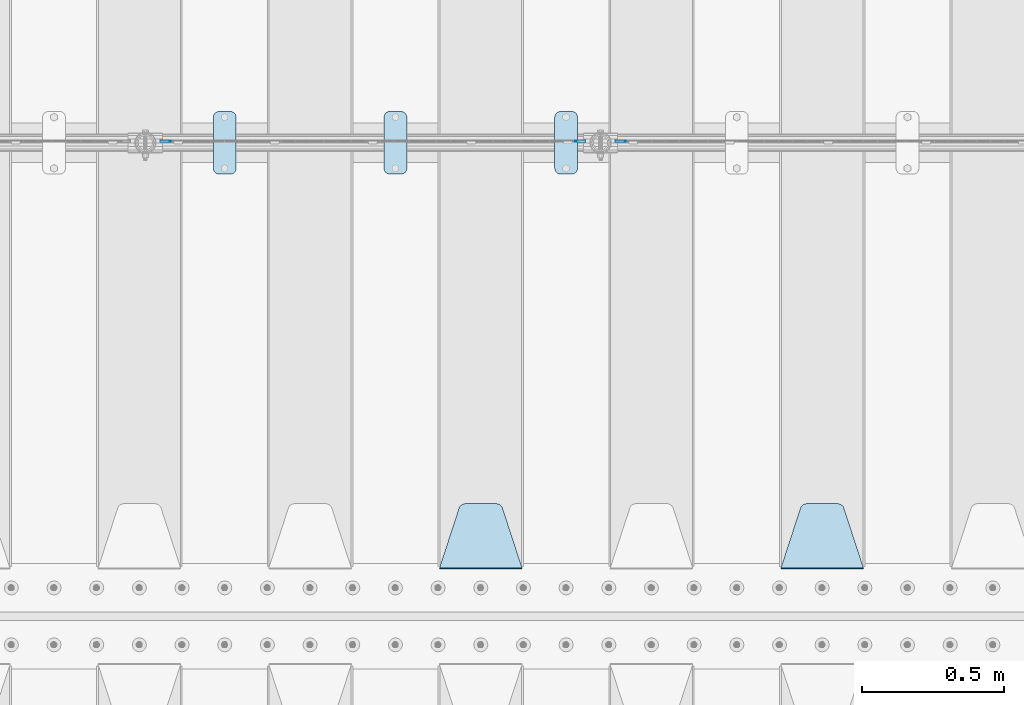
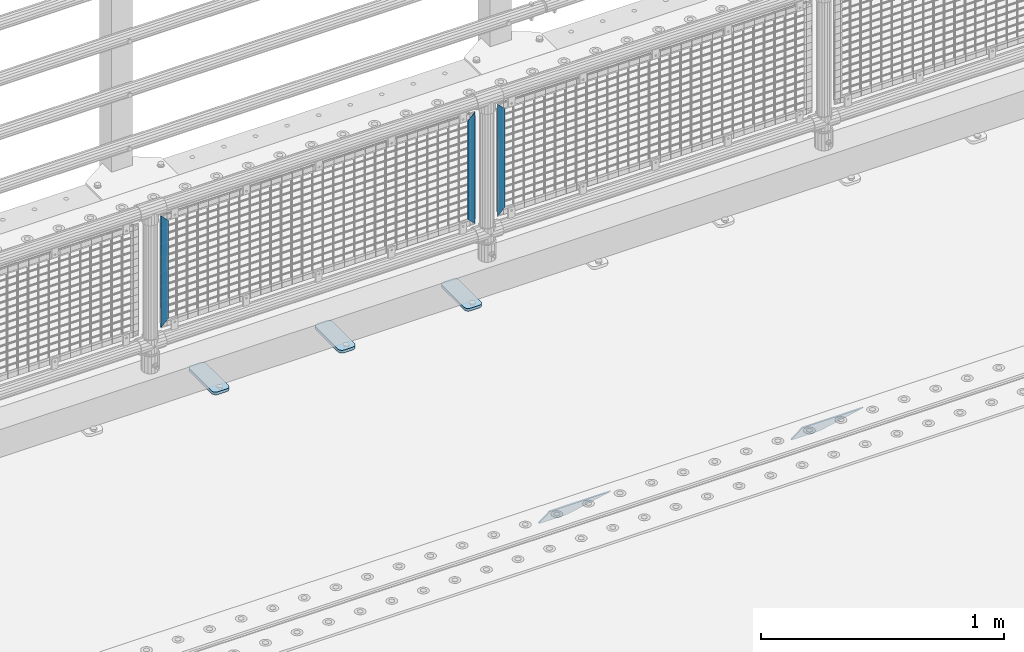
# One storey, part 181 of 208: 8 plates.
"""IFC2X3 building model written with IfcOpenShell, lengths in millimetres."""

from ifc_helpers import new_model, si_unit, frame, origin_with_axes, place, context, subcontext, project, spatial, faceted_brep, material, type_object, element, save


model = new_model("IFC2X3")

# Units and contexts
model_context = context("Model", 3, precision=1e-05, world=origin_with_axes())
body_context = subcontext(model_context, "Body", "Model", "MODEL_VIEW")
ifc_project = project(units=[si_unit("LENGTHUNIT", "METRE", prefix="MILLI"), si_unit("AREAUNIT", "SQUARE_METRE"), si_unit("VOLUMEUNIT", "CUBIC_METRE"), si_unit("MASSUNIT", "GRAM", prefix="KILO"), si_unit("TIMEUNIT", "SECOND"), si_unit("PLANEANGLEUNIT", "RADIAN"), si_unit("SOLIDANGLEUNIT", "STERADIAN"), si_unit("THERMODYNAMICTEMPERATUREUNIT", "DEGREE_CELSIUS"), si_unit("LUMINOUSINTENSITYUNIT", "LUMEN")], contexts=[model_context])

# Site, building, storey
site_placement = place(None, origin_with_axes())
site = spatial("IfcSite", under=ifc_project, at=site_placement, CompositionType="ELEMENT")
building_placement = place(site_placement, origin_with_axes())
building = spatial("IfcBuilding", under=site, at=building_placement, Name="Standard", CompositionType="ELEMENT")
storey_placement = place(building_placement, origin_with_axes())
storey = spatial("IfcBuildingStorey", under=building, at=storey_placement, Name="Undefined", CompositionType="ELEMENT", Elevation=0.0)

# Plates
ifc_material_1 = material(Name="STEEL/S355J2")
plate_type_1 = type_object("IfcPlateType", PredefinedType="NOTDEFINED")
plate_1_placement = place(storey_placement, frame((-33990.0, 4774.5, 21.0199999999977), z_axis=(1.0, 0.0, 0.0), x_axis=(0.0, -1.0, 0.0)))
element("IfcPlate", 1, at=plate_1_placement, inside=storey, type_object=plate_type_1, material=ifc_material_1, context=body_context, shape_type="Brep", body=[
    faceted_brep([(0.0, -7.0, 20.0), (0.0, -7.0, 60.0), (0.0, 7.0, 60.0), (0.0, 7.0, 20.0), (0.384294391935327, -7.0, 63.9018064403208), (0.384294391935327, 7.0, 63.9018064403208), (1.52240934977453, -7.0, 67.6536686473009), (1.52240934977453, 7.0, 67.6536686473009), (3.37060775394912, -7.0, 71.1114046603907), (3.37060775394912, 7.0, 71.1114046603907), (5.85786437626939, -7.0, 74.1421356237297), (5.85786437626939, 7.0, 74.1421356237297), (8.8885953396084, -7.0, 76.62939224605), (8.8885953396084, 7.0, 76.62939224605), (12.3463313526981, -7.0, 78.4775906502255), (12.3463313526981, 7.0, 78.4775906502255), (16.0981935596774, -7.0, 79.6157056080629), (16.0981935596774, 7.0, 79.6157056080629), (20.0, -7.0, 80.0), (20.0, 7.0, 80.0), (200.0, -7.0, 80.0), (200.0, 7.0, 80.0), (203.901806440323, -7.0, 79.6157056080629), (203.901806440323, 7.0, 79.6157056080629), (207.653668647302, -7.0, 78.4775906502255), (207.653668647302, 7.0, 78.4775906502255), (211.111404660393, -7.0, 76.62939224605), (211.111404660393, 7.0, 76.62939224605), (214.142135623731, -7.0, 74.1421356237297), (214.142135623731, 7.0, 74.1421356237297), (216.629392246051, -7.0, 71.1114046603907), (216.629392246051, 7.0, 71.1114046603907), (218.477590650225, -7.0, 67.6536686473009), (218.477590650225, 7.0, 67.6536686473009), (219.615705608065, -7.0, 63.9018064403208), (219.615705608065, 7.0, 63.9018064403208), (220.0, -7.0, 60.0), (220.0, 7.0, 60.0), (220.0, -7.0, 20.0), (220.0, 7.0, 20.0), (219.615705608065, -7.0, 16.0981935596792), (219.615705608065, 7.0, 16.0981935596792), (218.477590650225, -7.0, 12.3463313526991), (218.477590650225, 7.0, 12.3463313526991), (216.629392246051, -7.0, 8.88859533960931), (216.629392246051, 7.0, 8.88859533960931), (214.142135623731, -7.0, 5.8578643762703), (214.142135623731, 7.0, 5.8578643762703), (211.111404660393, -7.0, 3.37060775395003), (211.111404660393, 7.0, 3.37060775395003), (207.653668647302, -7.0, 1.52240934977453), (207.653668647302, 7.0, 1.52240934977453), (203.901806440323, -7.0, 0.384294391937146), (203.901806440323, 7.0, 0.384294391937146), (200.0, -7.0, 0.0), (200.0, 7.0, 0.0), (20.0, -7.0, 0.0), (20.0, 7.0, 0.0), (16.0981935596774, -7.0, 0.384294391937146), (16.0981935596774, 7.0, 0.384294391937146), (12.3463313526981, -7.0, 1.52240934977453), (12.3463313526981, 7.0, 1.52240934977453), (8.8885953396084, -7.0, 3.37060775395003), (8.8885953396084, 7.0, 3.37060775395003), (5.85786437626939, -7.0, 5.8578643762703), (5.85786437626939, 7.0, 5.8578643762703), (3.37060775394912, -7.0, 8.88859533960931), (3.37060775394912, 7.0, 8.88859533960931), (1.52240934977453, -7.0, 12.3463313526991), (1.52240934977453, 7.0, 12.3463313526991), (0.384294391935327, -7.0, 16.0981935596792), (0.384294391935327, 7.0, 16.0981935596792)], [[[0, 1, 2, 3]], [[1, 4, 5, 2]], [[4, 6, 7, 5]], [[6, 8, 9, 7]], [[8, 10, 11, 9]], [[10, 12, 13, 11]], [[12, 14, 15, 13]], [[14, 16, 17, 15]], [[16, 18, 19, 17]], [[18, 20, 21, 19]], [[20, 22, 23, 21]], [[22, 24, 25, 23]], [[24, 26, 27, 25]], [[26, 28, 29, 27]], [[28, 30, 31, 29]], [[30, 32, 33, 31]], [[32, 34, 35, 33]], [[34, 36, 37, 35]], [[36, 38, 39, 37]], [[38, 40, 41, 39]], [[40, 42, 43, 41]], [[42, 44, 45, 43]], [[44, 46, 47, 45]], [[46, 48, 49, 47]], [[48, 50, 51, 49]], [[50, 52, 53, 51]], [[52, 54, 55, 53]], [[54, 56, 57, 55]], [[56, 58, 59, 57]], [[58, 60, 61, 59]], [[60, 62, 63, 61]], [[62, 64, 65, 63]], [[64, 66, 67, 65]], [[66, 68, 69, 67]], [[68, 70, 71, 69]], [[70, 0, 3, 71]], [[5, 7, 9, 11, 13, 15, 17, 19, 21, 23, 25, 27, 29, 31, 33, 35, 37, 39, 41, 43, 45, 47, 49, 51, 53, 55, 57, 59, 61, 63, 65, 67, 69, 71, 3, 2]], [[70, 68, 66, 64, 62, 60, 58, 56, 54, 52, 50, 48, 46, 44, 42, 40, 38, 36, 34, 32, 30, 28, 26, 24, 22, 20, 18, 16, 14, 12, 10, 8, 6, 4, 1, 0]]]),
])
plate_2_placement = place(storey_placement, frame((-34590.0, 4774.5, 21.0199999999977), z_axis=(1.0, 0.0, 0.0), x_axis=(0.0, -1.0, 0.0)))
element("IfcPlate", 2, at=plate_2_placement, inside=storey, type_object=plate_type_1, material=ifc_material_1, context=body_context, shape_type="Brep", body=[
    faceted_brep([(0.0, -7.0, 20.0), (0.0, -7.0, 60.0), (0.0, 7.0, 60.0), (0.0, 7.0, 20.0), (0.384294391935327, -7.0, 63.9018064403208), (0.384294391935327, 7.0, 63.9018064403208), (1.52240934977453, -7.0, 67.6536686473009), (1.52240934977453, 7.0, 67.6536686473009), (3.37060775394912, -7.0, 71.1114046603907), (3.37060775394912, 7.0, 71.1114046603907), (5.85786437626939, -7.0, 74.1421356237297), (5.85786437626939, 7.0, 74.1421356237297), (8.8885953396084, -7.0, 76.62939224605), (8.8885953396084, 7.0, 76.62939224605), (12.3463313526981, -7.0, 78.4775906502255), (12.3463313526981, 7.0, 78.4775906502255), (16.0981935596774, -7.0, 79.6157056080629), (16.0981935596774, 7.0, 79.6157056080629), (20.0, -7.0, 80.0), (20.0, 7.0, 80.0), (200.0, -7.0, 80.0), (200.0, 7.0, 80.0), (203.901806440323, -7.0, 79.6157056080629), (203.901806440323, 7.0, 79.6157056080629), (207.653668647302, -7.0, 78.4775906502255), (207.653668647302, 7.0, 78.4775906502255), (211.111404660393, -7.0, 76.62939224605), (211.111404660393, 7.0, 76.62939224605), (214.142135623731, -7.0, 74.1421356237297), (214.142135623731, 7.0, 74.1421356237297), (216.629392246051, -7.0, 71.1114046603907), (216.629392246051, 7.0, 71.1114046603907), (218.477590650225, -7.0, 67.6536686473009), (218.477590650225, 7.0, 67.6536686473009), (219.615705608065, -7.0, 63.9018064403208), (219.615705608065, 7.0, 63.9018064403208), (220.0, -7.0, 60.0), (220.0, 7.0, 60.0), (220.0, -7.0, 20.0), (220.0, 7.0, 20.0), (219.615705608065, -7.0, 16.0981935596792), (219.615705608065, 7.0, 16.0981935596792), (218.477590650225, -7.0, 12.3463313526991), (218.477590650225, 7.0, 12.3463313526991), (216.629392246051, -7.0, 8.88859533960931), (216.629392246051, 7.0, 8.88859533960931), (214.142135623731, -7.0, 5.8578643762703), (214.142135623731, 7.0, 5.8578643762703), (211.111404660393, -7.0, 3.37060775395003), (211.111404660393, 7.0, 3.37060775395003), (207.653668647302, -7.0, 1.52240934977453), (207.653668647302, 7.0, 1.52240934977453), (203.901806440323, -7.0, 0.384294391937146), (203.901806440323, 7.0, 0.384294391937146), (200.0, -7.0, 0.0), (200.0, 7.0, 0.0), (20.0, -7.0, 0.0), (20.0, 7.0, 0.0), (16.0981935596774, -7.0, 0.384294391937146), (16.0981935596774, 7.0, 0.384294391937146), (12.3463313526981, -7.0, 1.52240934977453), (12.3463313526981, 7.0, 1.52240934977453), (8.8885953396084, -7.0, 3.37060775395003), (8.8885953396084, 7.0, 3.37060775395003), (5.85786437626939, -7.0, 5.8578643762703), (5.85786437626939, 7.0, 5.8578643762703), (3.37060775394912, -7.0, 8.88859533960931), (3.37060775394912, 7.0, 8.88859533960931), (1.52240934977453, -7.0, 12.3463313526991), (1.52240934977453, 7.0, 12.3463313526991), (0.384294391935327, -7.0, 16.0981935596792), (0.384294391935327, 7.0, 16.0981935596792)], [[[0, 1, 2, 3]], [[1, 4, 5, 2]], [[4, 6, 7, 5]], [[6, 8, 9, 7]], [[8, 10, 11, 9]], [[10, 12, 13, 11]], [[12, 14, 15, 13]], [[14, 16, 17, 15]], [[16, 18, 19, 17]], [[18, 20, 21, 19]], [[20, 22, 23, 21]], [[22, 24, 25, 23]], [[24, 26, 27, 25]], [[26, 28, 29, 27]], [[28, 30, 31, 29]], [[30, 32, 33, 31]], [[32, 34, 35, 33]], [[34, 36, 37, 35]], [[36, 38, 39, 37]], [[38, 40, 41, 39]], [[40, 42, 43, 41]], [[42, 44, 45, 43]], [[44, 46, 47, 45]], [[46, 48, 49, 47]], [[48, 50, 51, 49]], [[50, 52, 53, 51]], [[52, 54, 55, 53]], [[54, 56, 57, 55]], [[56, 58, 59, 57]], [[58, 60, 61, 59]], [[60, 62, 63, 61]], [[62, 64, 65, 63]], [[64, 66, 67, 65]], [[66, 68, 69, 67]], [[68, 70, 71, 69]], [[70, 0, 3, 71]], [[5, 7, 9, 11, 13, 15, 17, 19, 21, 23, 25, 27, 29, 31, 33, 35, 37, 39, 41, 43, 45, 47, 49, 51, 53, 55, 57, 59, 61, 63, 65, 67, 69, 71, 3, 2]], [[70, 68, 66, 64, 62, 60, 58, 56, 54, 52, 50, 48, 46, 44, 42, 40, 38, 36, 34, 32, 30, 28, 26, 24, 22, 20, 18, 16, 14, 12, 10, 8, 6, 4, 1, 0]]]),
])
plate_3_placement = place(storey_placement, frame((-35190.0, 4774.5, 21.0199999999977), z_axis=(1.0, 0.0, 0.0), x_axis=(0.0, -1.0, 0.0)))
element("IfcPlate", 3, at=plate_3_placement, inside=storey, type_object=plate_type_1, material=ifc_material_1, context=body_context, shape_type="Brep", body=[
    faceted_brep([(0.0, -7.0, 20.0), (0.0, -7.0, 60.0), (0.0, 7.0, 60.0), (0.0, 7.0, 20.0), (0.384294391935327, -7.0, 63.9018064403208), (0.384294391935327, 7.0, 63.9018064403208), (1.52240934977453, -7.0, 67.6536686473009), (1.52240934977453, 7.0, 67.6536686473009), (3.37060775394912, -7.0, 71.1114046603907), (3.37060775394912, 7.0, 71.1114046603907), (5.85786437626939, -7.0, 74.1421356237297), (5.85786437626939, 7.0, 74.1421356237297), (8.8885953396084, -7.0, 76.62939224605), (8.8885953396084, 7.0, 76.62939224605), (12.3463313526981, -7.0, 78.4775906502255), (12.3463313526981, 7.0, 78.4775906502255), (16.0981935596774, -7.0, 79.6157056080629), (16.0981935596774, 7.0, 79.6157056080629), (20.0, -7.0, 80.0), (20.0, 7.0, 80.0), (200.0, -7.0, 80.0), (200.0, 7.0, 80.0), (203.901806440323, -7.0, 79.6157056080629), (203.901806440323, 7.0, 79.6157056080629), (207.653668647302, -7.0, 78.4775906502255), (207.653668647302, 7.0, 78.4775906502255), (211.111404660393, -7.0, 76.62939224605), (211.111404660393, 7.0, 76.62939224605), (214.142135623731, -7.0, 74.1421356237297), (214.142135623731, 7.0, 74.1421356237297), (216.629392246051, -7.0, 71.1114046603907), (216.629392246051, 7.0, 71.1114046603907), (218.477590650225, -7.0, 67.6536686473009), (218.477590650225, 7.0, 67.6536686473009), (219.615705608065, -7.0, 63.9018064403208), (219.615705608065, 7.0, 63.9018064403208), (220.0, -7.0, 60.0), (220.0, 7.0, 60.0), (220.0, -7.0, 20.0), (220.0, 7.0, 20.0), (219.615705608065, -7.0, 16.0981935596792), (219.615705608065, 7.0, 16.0981935596792), (218.477590650225, -7.0, 12.3463313526991), (218.477590650225, 7.0, 12.3463313526991), (216.629392246051, -7.0, 8.88859533960931), (216.629392246051, 7.0, 8.88859533960931), (214.142135623731, -7.0, 5.8578643762703), (214.142135623731, 7.0, 5.8578643762703), (211.111404660393, -7.0, 3.37060775395003), (211.111404660393, 7.0, 3.37060775395003), (207.653668647302, -7.0, 1.52240934977453), (207.653668647302, 7.0, 1.52240934977453), (203.901806440323, -7.0, 0.384294391937146), (203.901806440323, 7.0, 0.384294391937146), (200.0, -7.0, 0.0), (200.0, 7.0, 0.0), (20.0, -7.0, 0.0), (20.0, 7.0, 0.0), (16.0981935596774, -7.0, 0.384294391937146), (16.0981935596774, 7.0, 0.384294391937146), (12.3463313526981, -7.0, 1.52240934977453), (12.3463313526981, 7.0, 1.52240934977453), (8.8885953396084, -7.0, 3.37060775395003), (8.8885953396084, 7.0, 3.37060775395003), (5.85786437626939, -7.0, 5.8578643762703), (5.85786437626939, 7.0, 5.8578643762703), (3.37060775394912, -7.0, 8.88859533960931), (3.37060775394912, 7.0, 8.88859533960931), (1.52240934977453, -7.0, 12.3463313526991), (1.52240934977453, 7.0, 12.3463313526991), (0.384294391935327, -7.0, 16.0981935596792), (0.384294391935327, 7.0, 16.0981935596792)], [[[0, 1, 2, 3]], [[1, 4, 5, 2]], [[4, 6, 7, 5]], [[6, 8, 9, 7]], [[8, 10, 11, 9]], [[10, 12, 13, 11]], [[12, 14, 15, 13]], [[14, 16, 17, 15]], [[16, 18, 19, 17]], [[18, 20, 21, 19]], [[20, 22, 23, 21]], [[22, 24, 25, 23]], [[24, 26, 27, 25]], [[26, 28, 29, 27]], [[28, 30, 31, 29]], [[30, 32, 33, 31]], [[32, 34, 35, 33]], [[34, 36, 37, 35]], [[36, 38, 39, 37]], [[38, 40, 41, 39]], [[40, 42, 43, 41]], [[42, 44, 45, 43]], [[44, 46, 47, 45]], [[46, 48, 49, 47]], [[48, 50, 51, 49]], [[50, 52, 53, 51]], [[52, 54, 55, 53]], [[54, 56, 57, 55]], [[56, 58, 59, 57]], [[58, 60, 61, 59]], [[60, 62, 63, 61]], [[62, 64, 65, 63]], [[64, 66, 67, 65]], [[66, 68, 69, 67]], [[68, 70, 71, 69]], [[70, 0, 3, 71]], [[5, 7, 9, 11, 13, 15, 17, 19, 21, 23, 25, 27, 29, 31, 33, 35, 37, 39, 41, 43, 45, 47, 49, 51, 53, 55, 57, 59, 61, 63, 65, 67, 69, 71, 3, 2]], [[70, 68, 66, 64, 62, 60, 58, 56, 54, 52, 50, 48, 46, 44, 42, 40, 38, 36, 34, 32, 30, 28, 26, 24, 22, 20, 18, 16, 14, 12, 10, 8, 6, 4, 1, 0]]]),
])
ifc_material_2 = material(Name="STEEL/S355N")
plate_type_2 = type_object("IfcPlateType", PredefinedType="NOTDEFINED")
plate_4_placement = place(storey_placement, frame((-32905.0, 3168.23223304702, -1.76776695296758), z_axis=(0.0, 0.707106781186547, -0.707106781186548), x_axis=(-1.0, 0.0, 0.0)))
element("IfcPlate", 4, at=plate_4_placement, inside=storey, type_object=plate_type_2, material=ifc_material_2, context=body_context, shape_type="Brep", body=[
    faceted_brep([(0.0, -2.5, 0.0), (69.345504679477, -2.5, 300.17173142483), (69.345504679477, 2.5, 300.17173142483), (0.0, 2.5, 0.0), (70.9274061199576, -2.5, 304.897442415399), (70.9274061199576, 2.5, 304.8974424154), (73.3818627772307, -2.5, 309.234538108527), (73.3818627772307, 2.5, 309.234538108527), (76.6187032999551, -2.5, 313.023683126103), (76.6187032999551, 2.5, 313.023683126103), (80.5190132704993, -2.5, 316.125672595371), (80.5190132704993, 2.5, 316.125672595371), (84.9395038596849, -2.5, 318.426546230476), (84.9395038596849, 2.50000000000091, 318.426546230476), (89.7177759439219, -2.5, 319.841774983275), (89.7177759439219, 2.50000000000091, 319.841774983275), (94.678286292652, -2.49999999999909, 320.319366455078), (94.678286292652, 2.5, 320.319366455078), (195.321713707348, -2.49999999999909, 320.319366455078), (195.321713707348, 2.5, 320.319366455078), (200.282224056078, -2.5, 319.841774983275), (200.282224056078, 2.5, 319.841774983274), (205.060496140315, -2.5, 318.426546230475), (205.060496140315, 2.5, 318.426546230475), (209.480986729501, -2.5, 316.125672595371), (209.480986729501, 2.50000000000091, 316.125672595371), (213.381296700045, -2.5, 313.023683126102), (213.381296700045, 2.5, 313.023683126102), (216.618137222769, -2.5, 309.234538108526), (216.618137222769, 2.5, 309.234538108527), (219.072593880042, -2.5, 304.897442415399), (219.072593880042, 2.5, 304.897442415399), (220.654495320523, -2.5, 300.17173142483), (220.654495320523, 2.5, 300.17173142483), (290.0, -2.5, 0.0), (290.0, 2.5, 0.0)], [[[0, 1, 2, 3]], [[1, 4, 5, 2]], [[4, 6, 7, 5]], [[6, 8, 9, 7]], [[8, 10, 11, 9]], [[10, 12, 13, 11]], [[12, 14, 15, 13]], [[14, 16, 17, 15]], [[16, 18, 19, 17]], [[18, 20, 21, 19]], [[20, 22, 23, 21]], [[22, 24, 25, 23]], [[24, 26, 27, 25]], [[26, 28, 29, 27]], [[28, 30, 31, 29]], [[30, 32, 33, 31]], [[32, 34, 35, 33]], [[34, 0, 3, 35]], [[5, 7, 9, 11, 13, 15, 17, 19, 21, 23, 25, 27, 29, 31, 33, 35, 3, 2]], [[34, 32, 30, 28, 26, 24, 22, 20, 18, 16, 14, 12, 10, 8, 6, 4, 1, 0]]]),
])
plate_5_placement = place(storey_placement, frame((-34105.0, 3168.23223304702, -1.76776695296758), z_axis=(0.0, 0.707106781186547, -0.707106781186548), x_axis=(-1.0, 0.0, 0.0)))
element("IfcPlate", 5, at=plate_5_placement, inside=storey, type_object=plate_type_2, material=ifc_material_2, context=body_context, shape_type="Brep", body=[
    faceted_brep([(0.0, -2.5, 0.0), (69.345504679477, -2.5, 300.17173142483), (69.345504679477, 2.5, 300.17173142483), (0.0, 2.5, 0.0), (70.9274061199576, -2.5, 304.897442415399), (70.9274061199576, 2.5, 304.8974424154), (73.3818627772307, -2.5, 309.234538108527), (73.3818627772307, 2.5, 309.234538108527), (76.6187032999551, -2.5, 313.023683126103), (76.6187032999551, 2.5, 313.023683126103), (80.5190132704993, -2.5, 316.125672595371), (80.5190132704993, 2.5, 316.125672595371), (84.9395038596849, -2.5, 318.426546230476), (84.9395038596849, 2.50000000000091, 318.426546230476), (89.7177759439219, -2.5, 319.841774983275), (89.7177759439219, 2.50000000000091, 319.841774983275), (94.678286292652, -2.49999999999909, 320.319366455078), (94.678286292652, 2.5, 320.319366455078), (195.321713707348, -2.49999999999909, 320.319366455078), (195.321713707348, 2.5, 320.319366455078), (200.282224056078, -2.5, 319.841774983275), (200.282224056078, 2.5, 319.841774983274), (205.060496140315, -2.5, 318.426546230475), (205.060496140315, 2.5, 318.426546230475), (209.480986729501, -2.5, 316.125672595371), (209.480986729501, 2.50000000000091, 316.125672595371), (213.381296700045, -2.5, 313.023683126102), (213.381296700045, 2.5, 313.023683126102), (216.618137222769, -2.5, 309.234538108526), (216.618137222769, 2.5, 309.234538108527), (219.072593880042, -2.5, 304.897442415399), (219.072593880042, 2.5, 304.897442415399), (220.654495320523, -2.5, 300.17173142483), (220.654495320523, 2.5, 300.17173142483), (290.0, -2.5, 0.0), (290.0, 2.5, 0.0)], [[[0, 1, 2, 3]], [[1, 4, 5, 2]], [[4, 6, 7, 5]], [[6, 8, 9, 7]], [[8, 10, 11, 9]], [[10, 12, 13, 11]], [[12, 14, 15, 13]], [[14, 16, 17, 15]], [[16, 18, 19, 17]], [[18, 20, 21, 19]], [[20, 22, 23, 21]], [[22, 24, 25, 23]], [[24, 26, 27, 25]], [[26, 28, 29, 27]], [[28, 30, 31, 29]], [[30, 32, 33, 31]], [[32, 34, 35, 33]], [[34, 0, 3, 35]], [[5, 7, 9, 11, 13, 15, 17, 19, 21, 23, 25, 27, 29, 31, 33, 35, 3, 2]], [[34, 32, 30, 28, 26, 24, 22, 20, 18, 16, 14, 12, 10, 8, 6, 4, 1, 0]]]),
])
ifc_material_3 = material(Name="Misc_Undefined")
plate_type_3 = type_object("IfcPlateType", PredefinedType="NOTDEFINED")
for number, where, z_axis, x_axis in (
    (6, (-33740.490286459, 4670.5, 879.519963133601), (-0.707008801899319, 0.0, -0.707204746899291), (-0.70720474689929, 0.0, 0.707008801899319)),
    (7, (-35340.490286459, 4670.5, 879.519963133601), (-0.707008801899319, 0.0, -0.707204746899291), (-0.70720474689929, 0.0, 0.707008801899319)),
):
    element("IfcPlate", number, at=place(storey_placement, frame(where, z_axis=z_axis, x_axis=x_axis)), inside=storey, type_object=plate_type_3, material=ifc_material_3, context=body_context, shape_type="Brep", body=[
        faceted_brep([(0.0, -1.49999999999909, 3.63797880709171e-12), (-348.55218505859, -1.5, 348.655029296875), (-348.55218505859, 1.5, 348.655029296875), (0.0, 1.50000000000182, 3.63797880709171e-12), (-348.544891357418, -1.5, 398.152496337894), (-348.544891357418, 1.5, 398.152496337894), (49.5043945312536, -1.5, 7.6397554948926e-11), (49.5043945312536, 1.5, 7.6397554948926e-11)], [[[0, 1, 2, 3]], [[1, 4, 5, 2]], [[4, 6, 7, 5]], [[6, 0, 3, 7]], [[5, 7, 3, 2]], [[6, 4, 1, 0]]]),
    ])
plate_6_placement = place(storey_placement, frame((-33917.5003125164, 4670.5, 879.52), z_axis=(0.707103624179499, 0.0, -0.707109938179501), x_axis=(0.707109938179495, 0.0, 0.707103624179505)))
element("IfcPlate", 8, at=plate_6_placement, inside=storey, type_object=plate_type_3, material=ifc_material_3, context=body_context, shape_type="Brep", body=[
    faceted_brep([(0.0, -1.49999999999909, 3.63797880709171e-12), (-348.605163574219, -1.5, 348.602081298821), (-348.605163574219, 1.5, 348.602081298821), (0.0, 1.50000000000182, 3.63797880709171e-12), (-348.605163574219, -1.5, 398.099334716793), (-348.605163574219, 1.5, 398.099334716793), (49.4976959228516, -1.5, 6.91215973347425e-11), (49.4976959228516, 1.5, 6.91215973347425e-11)], [[[0, 1, 2, 3]], [[1, 4, 5, 2]], [[4, 6, 7, 5]], [[6, 0, 3, 7]], [[5, 7, 3, 2]], [[6, 4, 1, 0]]]),
])

save(model, "model.ifc")
